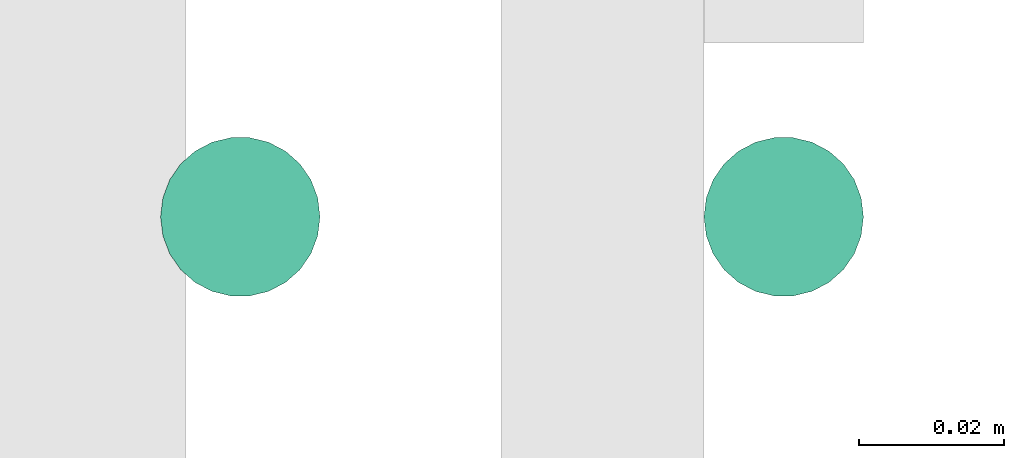
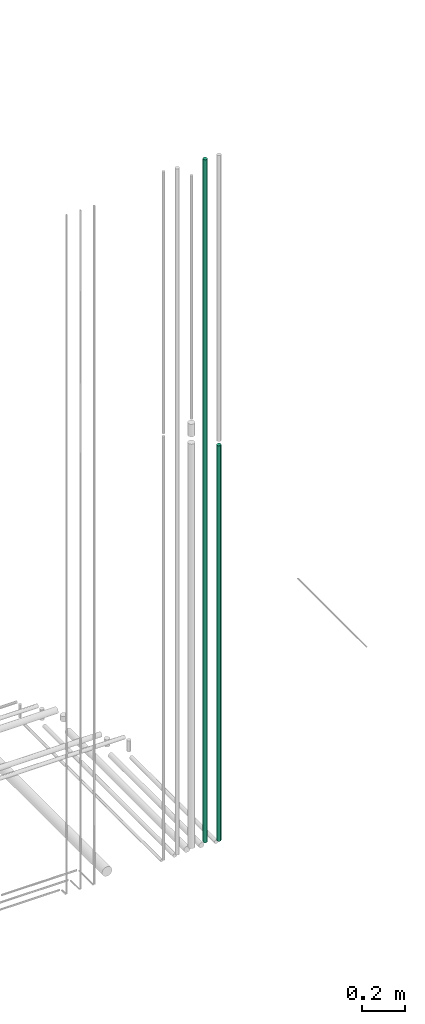
# One storey, part 94 of 331: 2 flow segments.
"""IFC2X3 building model written with IfcOpenShell, lengths in millimetres."""

from ifc_helpers import new_model, entity, si_unit, converted_unit, derived_unit, direction, frame, origin, origin_2d_with_axis, place, context, subcontext, project, spatial, circle, extrude, type_object, element, save


model = new_model("IFC2X3")

# Units and contexts
model_context = context("Model", 3, precision=0.01, world=origin(), true_north=direction((6.12303176911189e-17, 1.0)))
body_context = subcontext(model_context, "Body", "Model", "MODEL_VIEW")
ifc_project = project(units=[si_unit("LENGTHUNIT", "METRE", prefix="MILLI"), si_unit("AREAUNIT", "SQUARE_METRE"), si_unit("VOLUMEUNIT", "CUBIC_METRE"), converted_unit("PLANEANGLEUNIT", "DEGREE", entity("IfcRatioMeasure", 0.0174532925199433), si_unit("PLANEANGLEUNIT", "RADIAN"), dimensions=[0, 0, 0, 0, 0, 0, 0]), si_unit("MASSUNIT", "GRAM", prefix="KILO"), derived_unit("MASSDENSITYUNIT", [(si_unit("MASSUNIT", "GRAM", prefix="KILO"), 1), (si_unit("LENGTHUNIT", "METRE"), -3)]), derived_unit("MOMENTOFINERTIAUNIT", [(si_unit("LENGTHUNIT", "METRE"), 4)]), si_unit("TIMEUNIT", "SECOND"), si_unit("FREQUENCYUNIT", "HERTZ"), si_unit("THERMODYNAMICTEMPERATUREUNIT", "DEGREE_CELSIUS"), derived_unit("THERMALTRANSMITTANCEUNIT", [(si_unit("MASSUNIT", "GRAM", prefix="KILO"), 1), (si_unit("THERMODYNAMICTEMPERATUREUNIT", "KELVIN"), -1), (si_unit("TIMEUNIT", "SECOND"), -3)]), derived_unit("VOLUMETRICFLOWRATEUNIT", [(si_unit("LENGTHUNIT", "METRE"), 3), (si_unit("TIMEUNIT", "SECOND"), -1)]), derived_unit("MASSFLOWRATEUNIT", [(si_unit("MASSUNIT", "GRAM", prefix="KILO"), 1), (si_unit("TIMEUNIT", "SECOND"), -1)]), derived_unit("ROTATIONALFREQUENCYUNIT", [(si_unit("TIMEUNIT", "SECOND"), -1)]), si_unit("ELECTRICCURRENTUNIT", "AMPERE"), si_unit("ELECTRICVOLTAGEUNIT", "VOLT"), si_unit("POWERUNIT", "WATT"), si_unit("FORCEUNIT", "NEWTON", prefix="KILO"), si_unit("ILLUMINANCEUNIT", "LUX"), si_unit("LUMINOUSFLUXUNIT", "LUMEN"), si_unit("LUMINOUSINTENSITYUNIT", "CANDELA"), derived_unit("USERDEFINED", [(si_unit("MASSUNIT", "GRAM", prefix="KILO"), -1), (si_unit("LENGTHUNIT", "METRE"), -2), (si_unit("TIMEUNIT", "SECOND"), 3), (si_unit("LUMINOUSFLUXUNIT", "LUMEN"), 1)]), derived_unit("LINEARVELOCITYUNIT", [(si_unit("LENGTHUNIT", "METRE"), 1), (si_unit("TIMEUNIT", "SECOND"), -1)]), si_unit("PRESSUREUNIT", "PASCAL"), derived_unit("USERDEFINED", [(si_unit("LENGTHUNIT", "METRE"), -2), (si_unit("MASSUNIT", "GRAM", prefix="KILO"), 1), (si_unit("TIMEUNIT", "SECOND"), -2)]), derived_unit("LINEARFORCEUNIT", [(si_unit("MASSUNIT", "GRAM", prefix="KILO"), 1), (si_unit("LENGTHUNIT", "METRE"), 1), (si_unit("TIMEUNIT", "SECOND"), -2), (si_unit("LENGTHUNIT", "METRE"), -1)]), derived_unit("PLANARFORCEUNIT", [(si_unit("MASSUNIT", "GRAM", prefix="KILO"), 1), (si_unit("LENGTHUNIT", "METRE"), 1), (si_unit("TIMEUNIT", "SECOND"), -2), (si_unit("LENGTHUNIT", "METRE"), -2)])], contexts=[model_context])

# Site, building, storey
site_placement = place(None, frame((0.0, -0.00077364408347762, 0.0)))
site = spatial("IfcSite", under=ifc_project, at=site_placement, CompositionType="ELEMENT")
building_placement = place(site_placement, origin())
building = spatial("IfcBuilding", under=site, at=building_placement, CompositionType="ELEMENT")
storey_placement = place(building_placement, origin())
storey = spatial("IfcBuildingStorey", under=building, at=storey_placement, CompositionType="ELEMENT", Elevation=0.0)

# Flow segments
pipe_segment_type = type_object("IfcPipeSegmentType", PredefinedType="NOTDEFINED")
flow_segment_1_placement = place(building_placement, frame((65562.5166110417, 7652.55397754015, 18492.0)))
element("IfcFlowSegment", 1, at=flow_segment_1_placement, inside=storey, type_object=pipe_segment_type, context=body_context, shape_type="SweptSolid", body=[
    extrude(circle(Radius=11.0, at=origin_2d_with_axis()), frame((12.5952722359134, 12.5952722359156, 0.0), z_axis=(0.0, 0.0, 1.0), x_axis=(-1.0, 0.0, 0.0)), (0.0, 0.0, 1.0), 3909.00000000001),
])
flow_segment_2_placement = place(building_placement, frame((65637.5166110418, 7652.55397759734, 18473.9874126827)))
element("IfcFlowSegment", 2, at=flow_segment_2_placement, inside=storey, type_object=pipe_segment_type, context=body_context, shape_type="SweptSolid", body=[
    extrude(circle(Radius=11.0, at=origin_2d_with_axis()), frame((12.5952722359134, 12.5952722359156, 0.0)), (0.0, 0.0, 1.0), 2264.01258731729),
])

save(model, "model.ifc")
